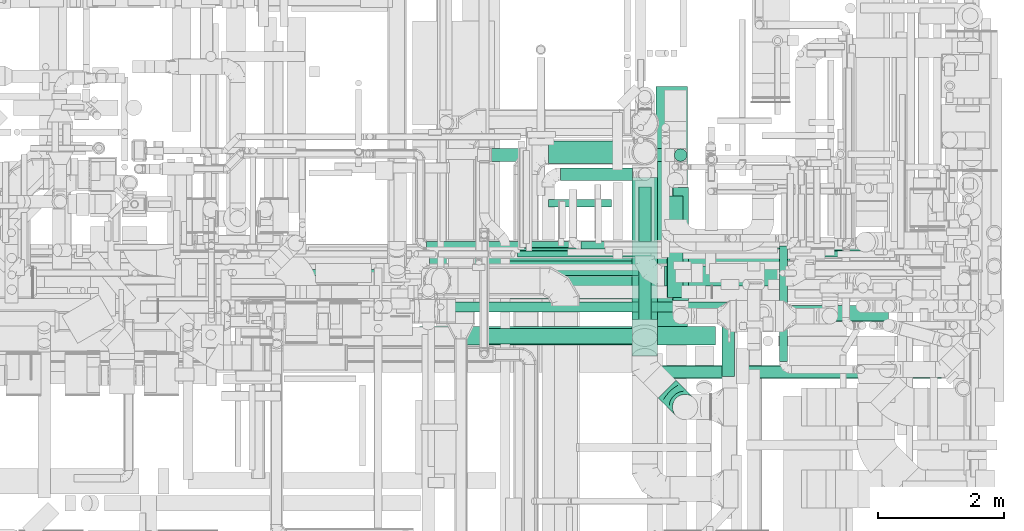
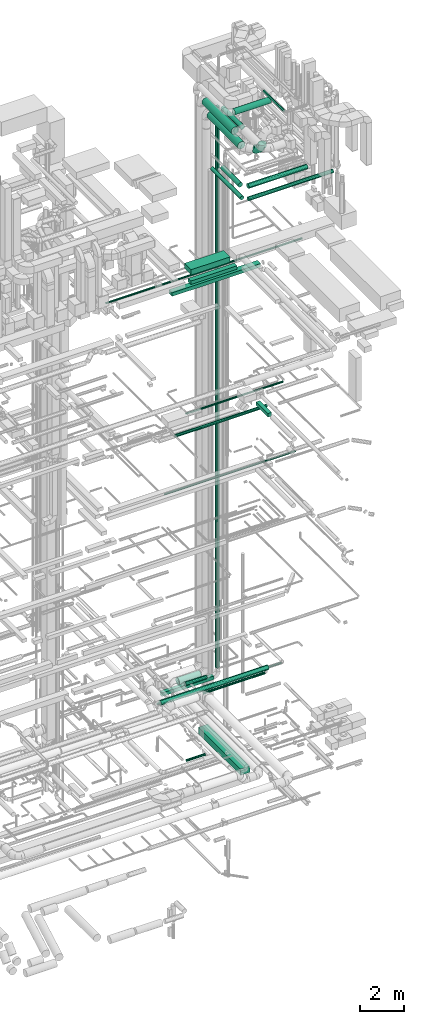
# One storey, part 63 of 337: 26 flow segments, 1 flow fitting.
"""IFC2X3 building model written with IfcOpenShell, lengths in millimetres."""

from ifc_helpers import new_model, entity, si_unit, converted_unit, derived_unit, direction, frame, origin, origin_2d_with_axis, place, context, subcontext, project, spatial, rectangle, circle, extrude, faceted_brep, source, transform, mapped, material, type_object, type_shapes, element, save


model = new_model("IFC2X3")

# Units and contexts
model_context = context("Model", 3, precision=0.01, world=origin(), true_north=direction((6.12303176911189e-17, 1.0)))
body_context = subcontext(model_context, "Body", "Model", "MODEL_VIEW")
ifc_project = project(units=[si_unit("LENGTHUNIT", "METRE", prefix="MILLI"), si_unit("AREAUNIT", "SQUARE_METRE"), si_unit("VOLUMEUNIT", "CUBIC_METRE"), converted_unit("PLANEANGLEUNIT", "DEGREE", entity("IfcRatioMeasure", 0.0174532925199433), si_unit("PLANEANGLEUNIT", "RADIAN"), dimensions=[0, 0, 0, 0, 0, 0, 0]), si_unit("MASSUNIT", "GRAM", prefix="KILO"), derived_unit("MASSDENSITYUNIT", [(si_unit("MASSUNIT", "GRAM", prefix="KILO"), 1), (si_unit("LENGTHUNIT", "METRE"), -3)]), derived_unit("MOMENTOFINERTIAUNIT", [(si_unit("LENGTHUNIT", "METRE"), 4)]), si_unit("TIMEUNIT", "SECOND"), si_unit("FREQUENCYUNIT", "HERTZ"), si_unit("THERMODYNAMICTEMPERATUREUNIT", "DEGREE_CELSIUS"), derived_unit("THERMALTRANSMITTANCEUNIT", [(si_unit("MASSUNIT", "GRAM", prefix="KILO"), 1), (si_unit("THERMODYNAMICTEMPERATUREUNIT", "KELVIN"), -1), (si_unit("TIMEUNIT", "SECOND"), -3)]), derived_unit("VOLUMETRICFLOWRATEUNIT", [(si_unit("LENGTHUNIT", "METRE"), 3), (si_unit("TIMEUNIT", "SECOND"), -1)]), derived_unit("MASSFLOWRATEUNIT", [(si_unit("MASSUNIT", "GRAM", prefix="KILO"), 1), (si_unit("TIMEUNIT", "SECOND"), -1)]), derived_unit("ROTATIONALFREQUENCYUNIT", [(si_unit("TIMEUNIT", "SECOND"), -1)]), si_unit("ELECTRICCURRENTUNIT", "AMPERE"), si_unit("ELECTRICVOLTAGEUNIT", "VOLT"), si_unit("POWERUNIT", "WATT"), si_unit("FORCEUNIT", "NEWTON", prefix="KILO"), si_unit("ILLUMINANCEUNIT", "LUX"), si_unit("LUMINOUSFLUXUNIT", "LUMEN"), si_unit("LUMINOUSINTENSITYUNIT", "CANDELA"), derived_unit("USERDEFINED", [(si_unit("MASSUNIT", "GRAM", prefix="KILO"), -1), (si_unit("LENGTHUNIT", "METRE"), -2), (si_unit("TIMEUNIT", "SECOND"), 3), (si_unit("LUMINOUSFLUXUNIT", "LUMEN"), 1)]), derived_unit("LINEARVELOCITYUNIT", [(si_unit("LENGTHUNIT", "METRE"), 1), (si_unit("TIMEUNIT", "SECOND"), -1)]), si_unit("PRESSUREUNIT", "PASCAL"), derived_unit("USERDEFINED", [(si_unit("LENGTHUNIT", "METRE"), -2), (si_unit("MASSUNIT", "GRAM", prefix="KILO"), 1), (si_unit("TIMEUNIT", "SECOND"), -2)]), derived_unit("LINEARFORCEUNIT", [(si_unit("MASSUNIT", "GRAM", prefix="KILO"), 1), (si_unit("LENGTHUNIT", "METRE"), 1), (si_unit("TIMEUNIT", "SECOND"), -2), (si_unit("LENGTHUNIT", "METRE"), -1)]), derived_unit("PLANARFORCEUNIT", [(si_unit("MASSUNIT", "GRAM", prefix="KILO"), 1), (si_unit("LENGTHUNIT", "METRE"), 1), (si_unit("TIMEUNIT", "SECOND"), -2), (si_unit("LENGTHUNIT", "METRE"), -2)])], contexts=[model_context])

# Site, building, storey
site_placement = place(None, origin())
site = spatial("IfcSite", under=ifc_project, at=site_placement, CompositionType="ELEMENT")
building_placement = place(site_placement, origin())
building = spatial("IfcBuilding", under=site, at=building_placement, CompositionType="ELEMENT")
storey_placement = place(building_placement, origin())
storey = spatial("IfcBuildingStorey", under=building, at=storey_placement, CompositionType="ELEMENT", Elevation=0.0)

# Flow segments
duct_segment_type_1 = type_object("IfcDuctSegmentType", PredefinedType="NOTDEFINED")
flow_segment_1_placement = place(storey_placement, frame((67739.12, 8950.37, -1095.0)))
element("IfcFlowSegment", 1, at=flow_segment_1_placement, inside=storey, type_object=duct_segment_type_1, context=body_context, shape_type="SweptSolid", body=[
    extrude(rectangle(XDim=3877.70991000002, YDim=499.999999999999, at=origin_2d_with_axis()), frame((250.0, 1938.85, 0.0), z_axis=(0.0, 0.0, 1.0), x_axis=(0.0, -1.0, 0.0)), (0.0, 0.0, 1.0), 350.0),
])
flow_segment_2_placement = place(storey_placement, frame((65134.49, 11644.28, 2600.0)))
element("IfcFlowSegment", 2, at=flow_segment_2_placement, inside=storey, type_object=duct_segment_type_1, context=body_context, shape_type="SweptSolid", body=[
    extrude(rectangle(XDim=2743.60561256579, YDim=200.0, at=origin_2d_with_axis()), frame((1371.8, 100.0, 0.0), z_axis=(0.0, 0.0, 1.0), x_axis=(-1.0, 0.0, 0.0)), (0.0, 0.0, 1.0), 200.0),
])
flow_segment_3_placement = place(storey_placement, frame((68780.94, 8236.78, 19050.0)))
element("IfcFlowSegment", 3, at=flow_segment_3_placement, inside=storey, type_object=duct_segment_type_1, context=body_context, shape_type="SweptSolid", body=[
    extrude(rectangle(XDim=1088.75000000003, YDim=199.999999999998, at=origin_2d_with_axis()), frame((100.0, 544.38, 0.0), z_axis=(0.0, 0.0, 1.0), x_axis=(0.0, -1.0, 0.0)), (0.0, 0.0, 1.0), 199.999999999998),
])
flow_segment_4_placement = place(storey_placement, frame((64991.73, 8750.02, 27500.0)))
element("IfcFlowSegment", 4, at=flow_segment_4_placement, inside=storey, type_object=duct_segment_type_1, context=body_context, shape_type="SweptSolid", body=[
    extrude(rectangle(XDim=2449.99999999995, YDim=249.999999999999, at=origin_2d_with_axis()), frame((1225.0, 125.0, 0.0)), (0.0, 0.0, 1.0), 199.999999999998),
])
flow_segment_5_placement = place(storey_placement, frame((65420.0, 9463.98, 27450.0)))
element("IfcFlowSegment", 5, at=flow_segment_5_placement, inside=storey, type_object=duct_segment_type_1, context=body_context, shape_type="SweptSolid", body=[
    extrude(rectangle(XDim=2071.64209774456, YDim=600.0, at=origin_2d_with_axis()), frame((1035.82, 300.0, 0.0)), (0.0, 0.0, 1.0), 300.000000000001),
])
flow_segment_6_placement = place(storey_placement, frame((63990.02, 8732.41, 27200.0)))
element("IfcFlowSegment", 6, at=flow_segment_6_placement, inside=storey, type_object=duct_segment_type_1, context=body_context, shape_type="SweptSolid", body=[
    extrude(rectangle(XDim=4690.60480000012, YDim=300.0, at=origin_2d_with_axis()), frame((2345.3, 150.0, 0.0)), (0.0, 0.0, 1.0), 199.999999999998),
])
duct_segment_type_2 = type_object("IfcDuctSegmentType", PredefinedType="NOTDEFINED")
flow_segment_7_placement = place(storey_placement, frame((66038.93, 10916.13, -964.1)))
element("IfcFlowSegment", 7, at=flow_segment_7_placement, inside=storey, type_object=duct_segment_type_2, context=body_context, shape_type="SweptSolid", body=[
    extrude(circle(Radius=62.5, at=origin_2d_with_axis()), frame((0.0, 64.1, 64.1), z_axis=(1.0, 0.0, 0.0), x_axis=(0.0, -1.0, 0.0)), (0.0, 0.0, 1.0), 995.793749999996),
])
flow_segment_8_placement = place(storey_placement, frame((66038.23, 11610.06, 2870.9)))
element("IfcFlowSegment", 8, at=flow_segment_8_placement, inside=storey, type_object=duct_segment_type_2, context=body_context, shape_type="SweptSolid", body=[
    extrude(circle(Radius=177.5, at=origin_2d_with_axis()), frame((0.0, 179.1, 179.1), z_axis=(1.0, 0.0, 0.0), x_axis=(0.0, -1.0, 0.0)), (0.0, 0.0, 1.0), 1169.95144825251),
])
flow_segment_9_placement = place(storey_placement, frame((68026.5, 11642.69, 3150.0)))
element("IfcFlowSegment", 9, at=flow_segment_9_placement, inside=storey, type_object=duct_segment_type_2, context=body_context, shape_type="SweptSolid", body=[
    extrude(circle(Radius=100.0, at=origin_2d_with_axis()), frame((101.6, 101.6, 0.0), z_axis=(0.0, 0.0, 1.0), x_axis=(0.0, 1.0, 0.0)), (0.0, 0.0, 1.0), 31450.0),
])
flow_segment_10_placement = place(storey_placement, frame((66229.36, 11337.75, 2948.4)))
element("IfcFlowSegment", 10, at=flow_segment_10_placement, inside=storey, type_object=duct_segment_type_2, context=body_context, shape_type="SweptSolid", body=[
    extrude(circle(Radius=100.0, at=origin_2d_with_axis()), frame((0.0, 101.6, 101.6), z_axis=(1.0, 0.0, 0.0), x_axis=(0.0, -1.0, 0.0)), (0.0, 0.0, 1.0), 1134.99784999365),
])
flow_segment_11_placement = place(storey_placement, frame((66546.95, 10251.41, 3035.9)))
element("IfcFlowSegment", 11, at=flow_segment_11_placement, inside=storey, type_object=duct_segment_type_2, context=body_context, shape_type="SweptSolid", body=[
    extrude(circle(Radius=62.5, at=origin_2d_with_axis()), frame((0.0, 64.1, 64.1), z_axis=(1.0, 0.0, 0.0), x_axis=(0.0, 1.0, 0.0)), (0.0, 0.0, 1.0), 3259.2640687119),
])
flow_segment_12_placement = place(storey_placement, frame((65542.48, 10127.45, 19148.4)))
element("IfcFlowSegment", 12, at=flow_segment_12_placement, inside=storey, type_object=duct_segment_type_2, context=body_context, shape_type="SweptSolid", body=[
    extrude(circle(Radius=50.0, at=origin_2d_with_axis()), frame((0.0, 51.6, 51.6), z_axis=(1.0, 0.0, 0.0), x_axis=(0.0, 1.0, 0.0)), (0.0, 0.0, 1.0), 5161.32864376276),
])
flow_segment_13_placement = place(storey_placement, frame((64465.03, 10223.45, 14948.4)))
element("IfcFlowSegment", 13, at=flow_segment_13_placement, inside=storey, type_object=duct_segment_type_2, context=body_context, shape_type="SweptSolid", body=[
    extrude(circle(Radius=50.0, at=origin_2d_with_axis()), frame((0.0, 51.6, 51.6), z_axis=(1.0, 0.0, 0.0), x_axis=(0.0, 1.0, 0.0)), (0.0, 0.0, 1.0), 6946.16370855841),
])
flow_segment_14_placement = place(storey_placement, frame((64491.97, 9256.98, 18753.4)))
element("IfcFlowSegment", 14, at=flow_segment_14_placement, inside=storey, type_object=duct_segment_type_2, context=body_context, shape_type="SweptSolid", body=[
    extrude(circle(Radius=80.0, at=origin_2d_with_axis()), frame((0.0, 81.6, 81.6), z_axis=(1.0, 0.0, 0.0), x_axis=(0.0, -1.0, 0.0)), (0.0, 0.0, 1.0), 4857.86796564405),
])
flow_segment_15_placement = place(storey_placement, frame((68001.5, 9443.7, 34673.4)))
element("IfcFlowSegment", 15, at=flow_segment_15_placement, inside=storey, type_object=duct_segment_type_2, context=body_context, shape_type="SweptSolid", body=[
    extrude(circle(Radius=125.0, at=origin_2d_with_axis()), frame((126.6, 0.0, 126.6), z_axis=(0.0, 1.0, 0.0), x_axis=(-1.0, 0.0, 0.0)), (0.0, 0.0, 1.0), 1783.40608810091),
])
flow_segment_16_placement = place(storey_placement, frame((67874.05, 9668.25, 35360.9)))
element("IfcFlowSegment", 16, at=flow_segment_16_placement, inside=storey, type_object=duct_segment_type_2, context=body_context, shape_type="SweptSolid", body=[
    extrude(circle(Radius=157.5, at=origin_2d_with_axis()), frame((0.0, 159.1, 159.1), z_axis=(1.0, 0.0, 0.0), x_axis=(0.0, -1.0, 0.0)), (0.0, 0.0, 1.0), 1917.20383818341),
])
flow_segment_17_placement = place(storey_placement, frame((69693.36, 8473.12, 35685.9)))
element("IfcFlowSegment", 17, at=flow_segment_17_placement, inside=storey, type_object=duct_segment_type_2, context=body_context, shape_type="SweptSolid", body=[
    extrude(circle(Radius=62.5, at=origin_2d_with_axis()), frame((64.1, 0.0, 64.1), z_axis=(0.0, 1.0, 0.0), x_axis=(1.0, 0.0, 0.0)), (0.0, 0.0, 1.0), 1829.14213562375),
])
flow_segment_18_placement = place(storey_placement, frame((67462.46, 8508.1, 31498.4)))
element("IfcFlowSegment", 18, at=flow_segment_18_placement, inside=storey, type_object=duct_segment_type_2, context=body_context, shape_type="SweptSolid", body=[
    extrude(circle(Radius=100.0, at=origin_2d_with_axis()), frame((101.6, 0.0, 101.6), z_axis=(0.0, 1.0, 0.0), x_axis=(-1.0, 0.0, 0.0)), (0.0, 0.0, 1.0), 2731.23808826895),
])
flow_segment_19_placement = place(storey_placement, frame((67764.05, 8206.51, 31498.4)))
element("IfcFlowSegment", 19, at=flow_segment_19_placement, inside=storey, type_object=duct_segment_type_2, context=body_context, shape_type="SweptSolid", body=[
    extrude(circle(Radius=100.0, at=origin_2d_with_axis()), frame((0.0, 101.6, 101.6), z_axis=(1.0, 0.0, 0.0), x_axis=(0.0, -1.0, 0.0)), (0.0, 0.0, 1.0), 4497.1572875254),
])
flow_segment_20_placement = place(storey_placement, frame((68290.58, 9109.26, 31448.4)))
element("IfcFlowSegment", 20, at=flow_segment_20_placement, inside=storey, type_object=duct_segment_type_2, context=body_context, shape_type="SweptSolid", body=[
    extrude(circle(Radius=125.0, at=origin_2d_with_axis()), frame((0.0, 126.6, 126.6), z_axis=(1.0, 0.0, 0.0), x_axis=(0.0, 1.0, 0.0)), (0.0, 0.0, 1.0), 3126.23367383135),
])
flow_segment_21_placement = place(storey_placement, frame((67913.98, 9485.86, 31448.4)))
element("IfcFlowSegment", 21, at=flow_segment_21_placement, inside=storey, type_object=duct_segment_type_2, context=body_context, shape_type="SweptSolid", body=[
    extrude(circle(Radius=125.0, at=origin_2d_with_axis()), frame((126.6, 0.0, 126.6), z_axis=(0.0, 1.0, 0.0), x_axis=(1.0, 0.0, 0.0)), (0.0, 0.0, 1.0), 1607.85601517859),
])
flow_segment_22_placement = place(storey_placement, frame((64102.18, 10273.39, 3298.4)))
element("IfcFlowSegment", 22, at=flow_segment_22_placement, inside=storey, type_object=duct_segment_type_2, context=body_context, shape_type="SweptSolid", body=[
    extrude(circle(Radius=50.0, at=origin_2d_with_axis()), frame((0.0, 51.6, 51.6), z_axis=(1.0, 0.0, 0.0), x_axis=(0.0, -1.0, 0.0)), (0.0, 0.0, 1.0), 6585.54965025766),
])
flow_segment_23_placement = place(storey_placement, frame((61131.29, 9829.93, 27068.4)))
element("IfcFlowSegment", 23, at=flow_segment_23_placement, inside=storey, type_object=duct_segment_type_2, context=body_context, shape_type="SweptSolid", body=[
    extrude(circle(Radius=50.0, at=origin_2d_with_axis()), frame((0.0, 51.6, 51.6), z_axis=(1.0, 0.0, 0.0), x_axis=(0.0, 1.0, 0.0)), (0.0, 0.0, 1.0), 10408.9363397005),
])
flow_segment_24_placement = place(storey_placement, frame((64147.96, 9990.09, 3393.4)))
element("IfcFlowSegment", 24, at=flow_segment_24_placement, inside=storey, type_object=duct_segment_type_2, context=body_context, shape_type="SweptSolid", body=[
    extrude(circle(Radius=125.0, at=origin_2d_with_axis()), frame((0.0, 126.6, 126.6), z_axis=(1.0, 0.0, 0.0), x_axis=(0.0, -1.0, 0.0)), (0.0, 0.0, 1.0), 5710.00000000001),
])
flow_segment_25_placement = place(storey_placement, frame((67357.46, 9137.83, 34798.4)))
element("IfcFlowSegment", 25, at=flow_segment_25_placement, inside=storey, type_object=duct_segment_type_2, context=body_context, shape_type="SweptSolid", body=[
    extrude(circle(Radius=200.0, at=origin_2d_with_axis()), frame((201.6, 0.0, 201.6), z_axis=(0.0, 1.0, 0.0), x_axis=(1.0, 0.0, 0.0)), (0.0, 0.0, 1.0), 2712.08714929301),
])
flow_segment_26_placement = place(storey_placement, frame((67357.45, 8560.2, 34318.4)))
element("IfcFlowSegment", 26, at=flow_segment_26_placement, inside=storey, type_object=duct_segment_type_2, context=body_context, shape_type="SweptSolid", body=[
    extrude(circle(Radius=200.0, at=origin_2d_with_axis()), frame((201.6, 0.0, 201.6), z_axis=(0.0, 1.0, 0.0), x_axis=(1.0, 0.0, 0.0)), (0.0, 0.0, 1.0), 2828.95862689451),
])

# Flow fitting
ifc_material = material()
duct_fitting_type = type_object("IfcDuctFittingType", PredefinedType="NOTDEFINED", material=ifc_material)
shared_shape = source(origin(), body_context, "Body", "Brep", [
    faceted_brep([(-400.0, 0.0, -200.0), (-400.0, -44.5, -194.99), (-400.0, -86.78, -180.19), (-400.0, -124.7, -156.37), (-400.0, -156.37, -124.7), (-400.0, -180.19, -86.78), (-400.0, -194.99, -44.5), (-400.0, -200.0, 0.0), (-400.0, -194.99, 44.5), (-400.0, -180.19, 86.78), (-400.0, -156.37, 124.7), (-400.0, -124.7, 156.37), (-400.0, -86.78, 180.19), (-400.0, -44.5, 194.99), (-400.0, 0.0, 200.0), (-400.0, 44.5, 194.99), (-400.0, 86.78, 180.19), (-400.0, 124.7, 156.37), (-400.0, 156.37, 124.7), (-400.0, 180.19, 86.78), (-400.0, 194.99, 44.5), (-400.0, 200.0, 0.0), (-400.0, 194.99, -44.5), (-400.0, 180.19, -86.78), (-400.0, 156.37, -124.7), (-400.0, 124.7, -156.37), (-400.0, 86.78, -180.19), (-400.0, 44.5, -194.99), (-292.82, 0.0, 200.0), (-304.75, 44.5, 194.99), (-316.07, 86.78, 180.19), (-326.23, 124.7, 156.37), (-334.72, 156.37, 124.7), (-341.1, 180.19, 86.78), (-345.07, 194.99, 44.5), (-346.41, 200.0, 0.0), (-345.07, 194.99, -44.5), (-341.1, 180.19, -86.78), (-334.72, 156.37, -124.7), (-326.23, 124.7, -156.37), (-316.07, 86.78, -180.19), (-304.75, 44.5, -194.99), (-292.82, 0.0, -200.0), (-280.9, -44.5, -194.99), (-269.57, -86.78, -180.19), (-259.41, -124.7, -156.37), (-250.92, -156.37, -124.7), (-244.54, -180.19, -86.78), (-240.57, -194.99, -44.5), (-239.23, -200.0, 0.0), (-240.57, -194.99, 44.5), (-244.54, -180.19, 86.78), (-250.92, -156.37, 124.7), (-259.41, -124.7, 156.37), (-269.57, -86.78, 180.19), (-280.9, -44.5, 194.99), (-107.18, 107.18, 200.0), (-139.76, 139.76, 194.99), (-170.7, 170.7, 180.19), (-198.46, 198.46, 156.37), (-221.65, 221.65, 124.7), (-239.09, 239.09, 86.78), (-249.92, 249.92, 44.5), (-253.59, 253.59, 0.0), (-249.92, 249.92, -44.5), (-239.09, 239.09, -86.78), (-221.65, 221.65, -124.7), (-198.46, 198.46, -156.37), (-170.7, 170.7, -180.19), (-139.76, 139.76, -194.99), (-107.18, 107.18, -200.0), (-74.6, 74.6, -194.99), (-43.65, 43.65, -180.19), (-15.89, 15.89, -156.37), (7.29, -7.29, -124.7), (24.73, -24.73, -86.78), (35.56, -35.56, -44.5), (39.23, -39.23, 0.0), (35.56, -35.56, 44.5), (24.73, -24.73, 86.78), (7.29, -7.29, 124.7), (-15.89, 15.89, 156.37), (-43.65, 43.65, 180.19), (-74.6, 74.6, 194.99), (0.0, 292.82, 200.0), (-44.5, 304.75, 194.99), (-86.78, 316.07, 180.19), (-124.7, 326.23, 156.37), (-156.37, 334.72, 124.7), (-180.19, 341.1, 86.78), (-194.99, 345.07, 44.5), (-200.0, 346.41, 0.0), (-194.99, 345.07, -44.5), (-180.19, 341.1, -86.78), (-156.37, 334.72, -124.7), (-124.7, 326.23, -156.37), (-86.78, 316.07, -180.19), (-44.5, 304.75, -194.99), (0.0, 292.82, -200.0), (44.5, 280.9, -194.99), (86.78, 269.57, -180.19), (124.7, 259.41, -156.37), (156.37, 250.92, -124.7), (180.19, 244.54, -86.78), (194.99, 240.57, -44.5), (200.0, 239.23, 0.0), (194.99, 240.57, 44.5), (180.19, 244.54, 86.78), (156.37, 250.92, 124.7), (124.7, 259.41, 156.37), (86.78, 269.57, 180.19), (44.5, 280.9, 194.99), (-44.5, 400.0, -194.99), (-86.78, 400.0, -180.19), (-124.7, 400.0, -156.37), (-156.37, 400.0, -124.7), (-180.19, 400.0, -86.78), (-194.99, 400.0, -44.5), (-200.0, 400.0, 0.0), (-194.99, 400.0, 44.5), (-180.19, 400.0, 86.78), (-156.37, 400.0, 124.7), (-124.7, 400.0, 156.37), (-86.78, 400.0, 180.19), (-44.5, 400.0, 194.99), (0.0, 400.0, 200.0), (44.5, 400.0, 194.99), (86.78, 400.0, 180.19), (124.7, 400.0, 156.37), (156.37, 400.0, 124.7), (180.19, 400.0, 86.78), (194.99, 400.0, 44.5), (200.0, 400.0, 0.0), (194.99, 400.0, -44.5), (180.19, 400.0, -86.78), (156.37, 400.0, -124.7), (124.7, 400.0, -156.37), (86.78, 400.0, -180.19), (44.5, 400.0, -194.99), (0.0, 400.0, -200.0)], [[[0, 1, 2, 3, 4, 5, 6, 7, 8, 9, 10, 11, 12, 13, 14, 15, 16, 17, 18, 19, 20, 21, 22, 23, 24, 25, 26, 27]], [[28, 29, 15, 14]], [[30, 31, 17, 16]], [[29, 30, 16, 15]], [[31, 32, 18, 17]], [[32, 33, 19, 18]], [[34, 35, 21, 20]], [[33, 34, 20, 19]], [[35, 36, 22, 21]], [[37, 38, 24, 23]], [[36, 37, 23, 22]], [[38, 39, 25, 24]], [[39, 40, 26, 25]], [[41, 42, 0, 27]], [[40, 41, 27, 26]], [[1, 0, 42, 43]], [[43, 44, 2, 1]], [[45, 3, 2, 44]], [[45, 46, 4, 3]], [[5, 4, 46, 47]], [[47, 48, 6, 5]], [[49, 7, 6, 48]], [[7, 49, 50, 8]], [[8, 50, 51, 9]], [[9, 51, 52, 10]], [[52, 53, 11, 10]], [[11, 53, 54, 12]], [[12, 54, 55, 13]], [[13, 55, 28, 14]], [[56, 57, 29, 28]], [[58, 59, 31, 30]], [[57, 58, 30, 29]], [[59, 60, 32, 31]], [[60, 61, 33, 32]], [[62, 63, 35, 34]], [[61, 62, 34, 33]], [[63, 64, 36, 35]], [[65, 66, 38, 37]], [[64, 65, 37, 36]], [[66, 67, 39, 38]], [[67, 68, 40, 39]], [[69, 70, 42, 41]], [[68, 69, 41, 40]], [[43, 42, 70, 71]], [[71, 72, 44, 43]], [[73, 45, 44, 72]], [[73, 74, 46, 45]], [[47, 46, 74, 75]], [[75, 76, 48, 47]], [[77, 49, 48, 76]], [[50, 49, 77, 78]], [[51, 50, 78, 79]], [[52, 51, 79, 80]], [[80, 81, 53, 52]], [[54, 53, 81, 82]], [[55, 54, 82, 83]], [[28, 55, 83, 56]], [[84, 85, 57, 56]], [[86, 87, 59, 58]], [[85, 86, 58, 57]], [[87, 88, 60, 59]], [[88, 89, 61, 60]], [[90, 91, 63, 62]], [[89, 90, 62, 61]], [[91, 92, 64, 63]], [[93, 94, 66, 65]], [[92, 93, 65, 64]], [[94, 95, 67, 66]], [[95, 96, 68, 67]], [[97, 98, 70, 69]], [[96, 97, 69, 68]], [[71, 70, 98, 99]], [[99, 100, 72, 71]], [[101, 73, 72, 100]], [[101, 102, 74, 73]], [[75, 74, 102, 103]], [[103, 104, 76, 75]], [[105, 77, 76, 104]], [[78, 77, 105, 106]], [[79, 78, 106, 107]], [[80, 79, 107, 108]], [[108, 109, 81, 80]], [[82, 81, 109, 110]], [[83, 82, 110, 111]], [[56, 83, 111, 84]], [[112, 113, 114, 115, 116, 117, 118, 119, 120, 121, 122, 123, 124, 125, 126, 127, 128, 129, 130, 131, 132, 133, 134, 135, 136, 137, 138, 139]], [[85, 84, 125, 124]], [[86, 85, 124, 123]], [[87, 86, 123, 122]], [[122, 121, 88, 87]], [[89, 88, 121, 120]], [[90, 89, 120, 119]], [[91, 90, 119, 118]], [[91, 118, 117, 92]], [[92, 117, 116, 93]], [[93, 116, 115, 94]], [[115, 114, 95, 94]], [[95, 114, 113, 96]], [[96, 113, 112, 97]], [[97, 112, 139, 98]], [[98, 139, 138, 99]], [[99, 138, 137, 100]], [[100, 137, 136, 101]], [[136, 135, 102, 101]], [[102, 135, 134, 103]], [[103, 134, 133, 104]], [[104, 133, 132, 105]], [[106, 105, 132, 131]], [[107, 106, 131, 130]], [[108, 107, 130, 129]], [[129, 128, 109, 108]], [[110, 109, 128, 127]], [[111, 110, 127, 126]], [[84, 111, 126, 125]]]),
])
type_shapes(duct_fitting_type, [shared_shape])
flow_fitting_placement = place(storey_placement, frame((68199.84, 7753.72, 34520.0), z_axis=(0.707106781186548, 0.707106781186547, 0.0), x_axis=(0.0, 0.0, -1.0)))
element("IfcFlowFitting", 27, at=flow_fitting_placement, inside=storey, type_object=duct_fitting_type, material=ifc_material, context=body_context, shape_type="MappedRepresentation", body=[
    mapped(shared_shape, transform((0.0, 0.0, 0.0), scale=1.0)),
])

save(model, "model.ifc")
